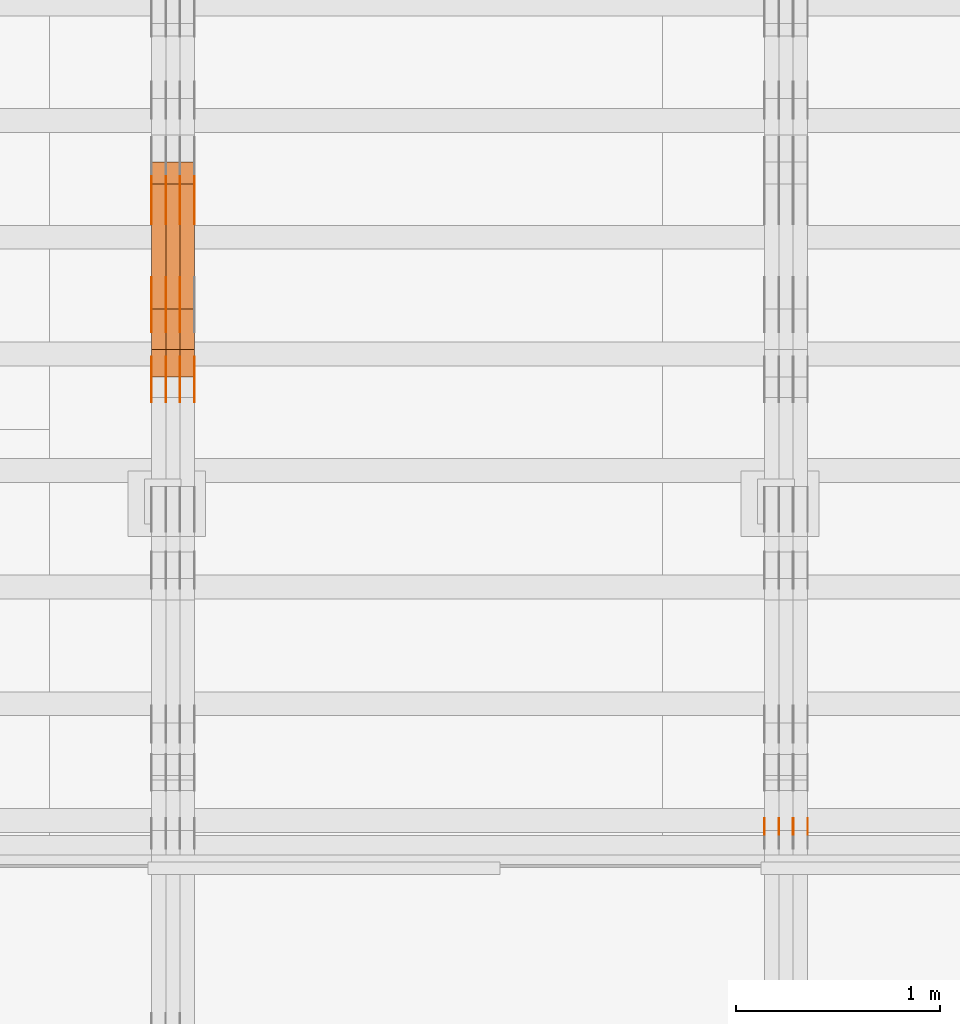
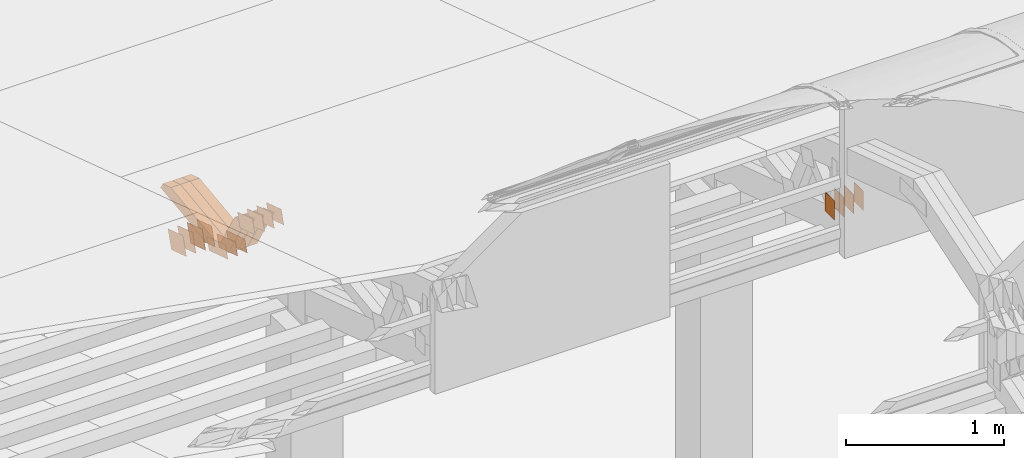
# One storey, part 101 of 385: 29 proxies.
"""IFC2X3 building model written with IfcOpenShell, lengths in millimetres."""

from ifc_helpers import new_model, entity, si_unit, converted_unit, derived_unit, direction, frame, origin, origin_2d_with_axis, place, context, subcontext, project, spatial, polyline, rectangle, outline, extrude, source, transform, mapped, material, type_object, type_shapes, element, save


model = new_model("IFC2X3")

# Units and contexts
model_context = context("Model", 3, precision=0.01, world=origin(), true_north=direction((6.12303176911189e-17, 1.0)))
body_context = subcontext(model_context, "Body", "Model", "MODEL_VIEW")
ifc_project = project(units=[si_unit("LENGTHUNIT", "METRE", prefix="MILLI"), si_unit("AREAUNIT", "SQUARE_METRE"), si_unit("VOLUMEUNIT", "CUBIC_METRE"), converted_unit("PLANEANGLEUNIT", "DEGREE", entity("IfcRatioMeasure", 0.0174532925199433), si_unit("PLANEANGLEUNIT", "RADIAN"), dimensions=[0, 0, 0, 0, 0, 0, 0]), si_unit("MASSUNIT", "GRAM", prefix="KILO"), derived_unit("MASSDENSITYUNIT", [(si_unit("MASSUNIT", "GRAM", prefix="KILO"), 1), (si_unit("LENGTHUNIT", "METRE"), -3)]), si_unit("TIMEUNIT", "SECOND"), si_unit("FREQUENCYUNIT", "HERTZ"), si_unit("THERMODYNAMICTEMPERATUREUNIT", "DEGREE_CELSIUS"), derived_unit("THERMALTRANSMITTANCEUNIT", [(si_unit("MASSUNIT", "GRAM", prefix="KILO"), 1), (si_unit("THERMODYNAMICTEMPERATUREUNIT", "KELVIN"), -1), (si_unit("TIMEUNIT", "SECOND"), -3)]), derived_unit("VOLUMETRICFLOWRATEUNIT", [(si_unit("LENGTHUNIT", "METRE"), 3), (si_unit("TIMEUNIT", "SECOND"), -1)]), si_unit("ELECTRICCURRENTUNIT", "AMPERE"), si_unit("ELECTRICVOLTAGEUNIT", "VOLT"), si_unit("POWERUNIT", "WATT"), si_unit("FORCEUNIT", "NEWTON", prefix="KILO"), si_unit("ILLUMINANCEUNIT", "LUX"), si_unit("LUMINOUSFLUXUNIT", "LUMEN"), si_unit("LUMINOUSINTENSITYUNIT", "CANDELA"), derived_unit("USERDEFINED", [(si_unit("MASSUNIT", "GRAM", prefix="KILO"), -1), (si_unit("LENGTHUNIT", "METRE"), -2), (si_unit("TIMEUNIT", "SECOND"), 3), (si_unit("LUMINOUSFLUXUNIT", "LUMEN"), 1)]), derived_unit("LINEARVELOCITYUNIT", [(si_unit("LENGTHUNIT", "METRE"), 1), (si_unit("TIMEUNIT", "SECOND"), -1)]), si_unit("PRESSUREUNIT", "PASCAL"), derived_unit("USERDEFINED", [(si_unit("LENGTHUNIT", "METRE"), -2), (si_unit("MASSUNIT", "GRAM", prefix="KILO"), 1), (si_unit("TIMEUNIT", "SECOND"), -2)])], contexts=[model_context])

# Site, building, storey
site_placement = place(None, origin())
site = spatial("IfcSite", under=ifc_project, at=site_placement, CompositionType="ELEMENT")
building_placement = place(site_placement, origin())
building = spatial("IfcBuilding", under=site, at=building_placement, CompositionType="ELEMENT")
storey_placement = place(building_placement, origin())
storey = spatial("IfcBuildingStorey", under=building, at=storey_placement, Name="Default", CompositionType="ELEMENT", Elevation=0.0)

# Proxies
ifc_material_1 = material(Name="IfcSurfaceStyle #170946")
building_element_proxy_type_1 = type_object("IfcBuildingElementProxyType", PredefinedType="NOTDEFINED", material=ifc_material_1)
shared_shape_1 = source(origin(), body_context, "Body", "SweptSolid", [
    extrude(rectangle(XDim=150.0, YDim=120.0, at=origin_2d_with_axis()), frame((75.0, 60.0, 0.0), z_axis=(0.0, 0.0, 1.0), x_axis=(-1.0, 0.0, 0.0)), (0.0, 0.0, 1.0), 1.3),
])
type_shapes(building_element_proxy_type_1, [shared_shape_1])
proxy_1_placement = place(building_placement, frame((12386.3, 15840.0, 3652.70166015625), z_axis=(-1.0, 0.0, 0.0), x_axis=(0.0, 0.0, -1.0)))
element("IfcBuildingElementProxy", 1, at=proxy_1_placement, inside=storey, type_object=building_element_proxy_type_1, material=ifc_material_1, context=body_context, shape_type="MappedRepresentation", body=[
    mapped(shared_shape_1, transform((0.0, 0.0, 0.0), scale=1.0)),
])
ifc_material_2 = material(Name="IfcSurfaceStyle #170889")
building_element_proxy_type_2 = type_object("IfcBuildingElementProxyType", PredefinedType="NOTDEFINED", material=ifc_material_2)
shared_shape_2 = source(origin(), body_context, "Body", "SweptSolid", [
    extrude(rectangle(XDim=150.0, YDim=120.0, at=origin_2d_with_axis()), frame((75.0, 60.0, 0.0), z_axis=(0.0, 0.0, 1.0), x_axis=(-1.0, 0.0, 0.0)), (0.0, 0.0, 1.0), 1.3),
])
type_shapes(building_element_proxy_type_2, [shared_shape_2])
proxy_2_placement = place(building_placement, frame((12315.0, 15840.0, 3652.70166015625), z_axis=(-1.0, 0.0, 0.0), x_axis=(0.0, 0.0, -1.0)))
element("IfcBuildingElementProxy", 2, at=proxy_2_placement, inside=storey, type_object=building_element_proxy_type_2, material=ifc_material_2, context=body_context, shape_type="MappedRepresentation", body=[
    mapped(shared_shape_2, transform((0.0, 0.0, 0.0), scale=1.0)),
])
ifc_material_3 = material(Name="IfcSurfaceStyle #170832")
building_element_proxy_type_3 = type_object("IfcBuildingElementProxyType", PredefinedType="NOTDEFINED", material=ifc_material_3)
shared_shape_3 = source(origin(), body_context, "Body", "SweptSolid", [
    extrude(rectangle(XDim=150.0, YDim=120.0, at=origin_2d_with_axis()), frame((75.0, 60.0, 0.0), z_axis=(0.0, 0.0, 1.0), x_axis=(-1.0, 0.0, 0.0)), (0.0, 0.0, 1.0), 1.3),
])
type_shapes(building_element_proxy_type_3, [shared_shape_3])
proxy_3_placement = place(building_placement, frame((12316.3, 15840.0, 3652.70166015625), z_axis=(-1.0, 0.0, 0.0), x_axis=(0.0, 0.0, -1.0)))
element("IfcBuildingElementProxy", 3, at=proxy_3_placement, inside=storey, type_object=building_element_proxy_type_3, material=ifc_material_3, context=body_context, shape_type="MappedRepresentation", body=[
    mapped(shared_shape_3, transform((0.0, 0.0, 0.0), scale=1.0)),
])
ifc_material_4 = material(Name="IfcSurfaceStyle #170775")
building_element_proxy_type_4 = type_object("IfcBuildingElementProxyType", PredefinedType="NOTDEFINED", material=ifc_material_4)
shared_shape_4 = source(origin(), body_context, "Body", "SweptSolid", [
    extrude(rectangle(XDim=150.0, YDim=120.0, at=origin_2d_with_axis()), frame((75.0, 60.0, 0.0), z_axis=(0.0, 0.0, 1.0), x_axis=(-1.0, 0.0, 0.0)), (0.0, 0.0, 1.0), 1.29999999999999),
])
type_shapes(building_element_proxy_type_4, [shared_shape_4])
proxy_4_placement = place(building_placement, frame((12245.0, 15840.0, 3652.70166015625), z_axis=(-1.0, 0.0, 0.0), x_axis=(0.0, 0.0, -1.0)))
element("IfcBuildingElementProxy", 4, at=proxy_4_placement, inside=storey, type_object=building_element_proxy_type_4, material=ifc_material_4, context=body_context, shape_type="MappedRepresentation", body=[
    mapped(shared_shape_4, transform((0.0, 0.0, 0.0), scale=1.0)),
])
ifc_material_5 = material(Name="IfcSurfaceStyle #170718")
building_element_proxy_type_5 = type_object("IfcBuildingElementProxyType", PredefinedType="NOTDEFINED", material=ifc_material_5)
shared_shape_5 = source(origin(), body_context, "Body", "SweptSolid", [
    extrude(rectangle(XDim=150.0, YDim=120.0, at=origin_2d_with_axis()), frame((75.0, 60.0, 0.0), z_axis=(0.0, 0.0, 1.0), x_axis=(-1.0, 0.0, 0.0)), (0.0, 0.0, 1.0), 1.29999999999999),
])
type_shapes(building_element_proxy_type_5, [shared_shape_5])
proxy_5_placement = place(building_placement, frame((12246.3, 15840.0, 3652.70166015625), z_axis=(-1.0, 0.0, 0.0), x_axis=(0.0, 0.0, -1.0)))
element("IfcBuildingElementProxy", 5, at=proxy_5_placement, inside=storey, type_object=building_element_proxy_type_5, material=ifc_material_5, context=body_context, shape_type="MappedRepresentation", body=[
    mapped(shared_shape_5, transform((0.0, 0.0, 0.0), scale=1.0)),
])
ifc_material_6 = material(Name="IfcSurfaceStyle #170661")
building_element_proxy_type_6 = type_object("IfcBuildingElementProxyType", PredefinedType="NOTDEFINED", material=ifc_material_6)
shared_shape_6 = source(origin(), body_context, "Body", "SweptSolid", [
    extrude(rectangle(XDim=150.0, YDim=120.0, at=origin_2d_with_axis()), frame((75.0, 60.0, 0.0), z_axis=(0.0, 0.0, 1.0), x_axis=(-1.0, 0.0, 0.0)), (0.0, 0.0, 1.0), 1.29999999999999),
])
type_shapes(building_element_proxy_type_6, [shared_shape_6])
proxy_6_placement = place(building_placement, frame((12175.0, 15840.0, 3652.70166015625), z_axis=(-1.0, 0.0, 0.0), x_axis=(0.0, 0.0, -1.0)))
element("IfcBuildingElementProxy", 6, at=proxy_6_placement, inside=storey, type_object=building_element_proxy_type_6, material=ifc_material_6, context=body_context, shape_type="MappedRepresentation", body=[
    mapped(shared_shape_6, transform((0.0, 0.0, 0.0), scale=1.0)),
])
ifc_material_7 = material(Name="IfcSurfaceStyle #135773")
building_element_proxy_type_7 = type_object("IfcBuildingElementProxyType", PredefinedType="NOTDEFINED", material=ifc_material_7)
shared_shape_7 = source(origin(), body_context, "Body", "SweptSolid", [
    extrude(outline(polyline([(-125.00031378339, -47.9999612158856), (125.000225258022, -47.9999612158856), (124.999811678525, 47.9999612158856), (-124.999723153156, 47.9999612158856), (-125.00031378339, -47.9999612158856)])), frame((125.000225258022, 48.0000091013474, 0.0), z_axis=(0.0, 0.0, 1.0), x_axis=(-1.0, 0.0, 0.0)), (0.0, 0.0, 1.0), 1.3),
])
type_shapes(building_element_proxy_type_7, [shared_shape_7])
proxy_7_placement = place(building_placement, frame((9315.0, 18456.8597683375, 2657.46691321253), z_axis=(-1.0, 0.0, 0.0), x_axis=(0.0, -0.951056516295124, 0.309016994375039)))
element("IfcBuildingElementProxy", 7, at=proxy_7_placement, inside=storey, type_object=building_element_proxy_type_7, material=ifc_material_7, context=body_context, shape_type="MappedRepresentation", body=[
    mapped(shared_shape_7, transform((0.0, 0.0, 0.0), scale=1.0)),
])
ifc_material_8 = material(Name="IfcSurfaceStyle #135716")
building_element_proxy_type_8 = type_object("IfcBuildingElementProxyType", PredefinedType="NOTDEFINED", material=ifc_material_8)
shared_shape_8 = source(origin(), body_context, "Body", "SweptSolid", [
    extrude(outline(polyline([(-125.00031378339, -47.9999612158856), (125.000225258022, -47.9999612158856), (124.999811678525, 47.9999612158856), (-124.999723153156, 47.9999612158856), (-125.00031378339, -47.9999612158856)])), frame((125.000225258022, 48.0000091013474, 0.0), z_axis=(0.0, 0.0, 1.0), x_axis=(-1.0, 0.0, 0.0)), (0.0, 0.0, 1.0), 1.3),
])
type_shapes(building_element_proxy_type_8, [shared_shape_8])
proxy_8_placement = place(building_placement, frame((9316.29999999998, 18456.8597683375, 2657.46691321253), z_axis=(-1.0, 0.0, 0.0), x_axis=(0.0, -0.951056516295124, 0.309016994375039)))
element("IfcBuildingElementProxy", 8, at=proxy_8_placement, inside=storey, type_object=building_element_proxy_type_8, material=ifc_material_8, context=body_context, shape_type="MappedRepresentation", body=[
    mapped(shared_shape_8, transform((0.0, 0.0, 0.0), scale=1.0)),
])
ifc_material_9 = material(Name="IfcSurfaceStyle #135659")
building_element_proxy_type_9 = type_object("IfcBuildingElementProxyType", PredefinedType="NOTDEFINED", material=ifc_material_9)
shared_shape_9 = source(origin(), body_context, "Body", "SweptSolid", [
    extrude(outline(polyline([(-125.00031378339, -47.9999612158856), (125.000225258022, -47.9999612158856), (124.999811678525, 47.9999612158856), (-124.999723153156, 47.9999612158856), (-125.00031378339, -47.9999612158856)])), frame((125.000225258022, 48.0000091013474, 0.0), z_axis=(0.0, 0.0, 1.0), x_axis=(-1.0, 0.0, 0.0)), (0.0, 0.0, 1.0), 1.29999999999998),
])
type_shapes(building_element_proxy_type_9, [shared_shape_9])
proxy_9_placement = place(building_placement, frame((9245.0, 18456.8597683375, 2657.46691321253), z_axis=(-1.0, 0.0, 0.0), x_axis=(0.0, -0.951056516295124, 0.309016994375039)))
element("IfcBuildingElementProxy", 9, at=proxy_9_placement, inside=storey, type_object=building_element_proxy_type_9, material=ifc_material_9, context=body_context, shape_type="MappedRepresentation", body=[
    mapped(shared_shape_9, transform((0.0, 0.0, 0.0), scale=1.0)),
])
ifc_material_10 = material(Name="IfcSurfaceStyle #135602")
building_element_proxy_type_10 = type_object("IfcBuildingElementProxyType", PredefinedType="NOTDEFINED", material=ifc_material_10)
shared_shape_10 = source(origin(), body_context, "Body", "SweptSolid", [
    extrude(outline(polyline([(-125.00031378339, -47.9999612158856), (125.000225258022, -47.9999612158856), (124.999811678525, 47.9999612158856), (-124.999723153156, 47.9999612158856), (-125.00031378339, -47.9999612158856)])), frame((125.000225258022, 48.0000091013474, 0.0), z_axis=(0.0, 0.0, 1.0), x_axis=(-1.0, 0.0, 0.0)), (0.0, 0.0, 1.0), 1.29999999999998),
])
type_shapes(building_element_proxy_type_10, [shared_shape_10])
proxy_10_placement = place(building_placement, frame((9246.29999999998, 18456.8597683375, 2657.46691321253), z_axis=(-1.0, 0.0, 0.0), x_axis=(0.0, -0.951056516295124, 0.309016994375039)))
element("IfcBuildingElementProxy", 10, at=proxy_10_placement, inside=storey, type_object=building_element_proxy_type_10, material=ifc_material_10, context=body_context, shape_type="MappedRepresentation", body=[
    mapped(shared_shape_10, transform((0.0, 0.0, 0.0), scale=1.0)),
])
ifc_material_11 = material(Name="IfcSurfaceStyle #135545")
building_element_proxy_type_11 = type_object("IfcBuildingElementProxyType", PredefinedType="NOTDEFINED", material=ifc_material_11)
shared_shape_11 = source(origin(), body_context, "Body", "SweptSolid", [
    extrude(outline(polyline([(-125.00031378339, -47.9999612158856), (125.000225258022, -47.9999612158856), (124.999811678525, 47.9999612158856), (-124.999723153156, 47.9999612158856), (-125.00031378339, -47.9999612158856)])), frame((125.000225258022, 48.0000091013474, 0.0), z_axis=(0.0, 0.0, 1.0), x_axis=(-1.0, 0.0, 0.0)), (0.0, 0.0, 1.0), 1.29999999999998),
])
type_shapes(building_element_proxy_type_11, [shared_shape_11])
proxy_11_placement = place(building_placement, frame((9175.0, 18456.8597683375, 2657.46691321253), z_axis=(-1.0, 0.0, 0.0), x_axis=(0.0, -0.951056516295124, 0.309016994375039)))
element("IfcBuildingElementProxy", 11, at=proxy_11_placement, inside=storey, type_object=building_element_proxy_type_11, material=ifc_material_11, context=body_context, shape_type="MappedRepresentation", body=[
    mapped(shared_shape_11, transform((0.0, 0.0, 0.0), scale=1.0)),
])
ifc_material_12 = material(Name="IfcSurfaceStyle #134120")
building_element_proxy_type_12 = type_object("IfcBuildingElementProxyType", PredefinedType="NOTDEFINED", material=ifc_material_12)
shared_shape_12 = source(origin(), body_context, "Body", "SweptSolid", [
    extrude(outline(polyline([(-99.999796294464, -72.0000050220467), (99.9998768370438, -72.0000050220467), (100.000260677528, 72.0000050220467), (-100.000341220108, 72.0000050220467), (-99.999796294464, -72.0000050220467)])), frame((100.000260677528, 72.0000050220467, 0.0), z_axis=(0.0, 0.0, 1.0), x_axis=(-1.0, 0.0, 0.0)), (0.0, 0.0, 1.0), 1.3),
])
type_shapes(building_element_proxy_type_12, [shared_shape_12])
proxy_12_placement = place(building_placement, frame((9386.29999999998, 18936.3876569477, 2373.90613192527), z_axis=(-1.0, 0.0, 0.0), x_axis=(0.0, -0.951056516295124, 0.309016994375039)))
element("IfcBuildingElementProxy", 12, at=proxy_12_placement, inside=storey, type_object=building_element_proxy_type_12, material=ifc_material_12, context=body_context, shape_type="MappedRepresentation", body=[
    mapped(shared_shape_12, transform((0.0, 0.0, 0.0), scale=1.0)),
])
ifc_material_13 = material(Name="IfcSurfaceStyle #134063")
building_element_proxy_type_13 = type_object("IfcBuildingElementProxyType", PredefinedType="NOTDEFINED", material=ifc_material_13)
shared_shape_13 = source(origin(), body_context, "Body", "SweptSolid", [
    extrude(outline(polyline([(-99.999796294464, -72.0000050220467), (99.9998768370438, -72.0000050220467), (100.000260677528, 72.0000050220467), (-100.000341220108, 72.0000050220467), (-99.999796294464, -72.0000050220467)])), frame((100.000260677528, 72.0000050220467, 0.0), z_axis=(0.0, 0.0, 1.0), x_axis=(-1.0, 0.0, 0.0)), (0.0, 0.0, 1.0), 1.3),
])
type_shapes(building_element_proxy_type_13, [shared_shape_13])
proxy_13_placement = place(building_placement, frame((9315.0, 18936.3876569477, 2373.90613192527), z_axis=(-1.0, 0.0, 0.0), x_axis=(0.0, -0.951056516295124, 0.309016994375039)))
element("IfcBuildingElementProxy", 13, at=proxy_13_placement, inside=storey, type_object=building_element_proxy_type_13, material=ifc_material_13, context=body_context, shape_type="MappedRepresentation", body=[
    mapped(shared_shape_13, transform((0.0, 0.0, 0.0), scale=1.0)),
])
ifc_material_14 = material(Name="IfcSurfaceStyle #134006")
building_element_proxy_type_14 = type_object("IfcBuildingElementProxyType", PredefinedType="NOTDEFINED", material=ifc_material_14)
shared_shape_14 = source(origin(), body_context, "Body", "SweptSolid", [
    extrude(outline(polyline([(-99.999796294464, -72.0000050220467), (99.9998768370438, -72.0000050220467), (100.000260677528, 72.0000050220467), (-100.000341220108, 72.0000050220467), (-99.999796294464, -72.0000050220467)])), frame((100.000260677528, 72.0000050220467, 0.0), z_axis=(0.0, 0.0, 1.0), x_axis=(-1.0, 0.0, 0.0)), (0.0, 0.0, 1.0), 1.3),
])
type_shapes(building_element_proxy_type_14, [shared_shape_14])
proxy_14_placement = place(building_placement, frame((9316.29999999998, 18936.3876569477, 2373.90613192527), z_axis=(-1.0, 0.0, 0.0), x_axis=(0.0, -0.951056516295124, 0.309016994375039)))
element("IfcBuildingElementProxy", 14, at=proxy_14_placement, inside=storey, type_object=building_element_proxy_type_14, material=ifc_material_14, context=body_context, shape_type="MappedRepresentation", body=[
    mapped(shared_shape_14, transform((0.0, 0.0, 0.0), scale=1.0)),
])
ifc_material_15 = material(Name="IfcSurfaceStyle #133949")
building_element_proxy_type_15 = type_object("IfcBuildingElementProxyType", PredefinedType="NOTDEFINED", material=ifc_material_15)
shared_shape_15 = source(origin(), body_context, "Body", "SweptSolid", [
    extrude(outline(polyline([(-99.999796294464, -72.0000050220467), (99.9998768370438, -72.0000050220467), (100.000260677528, 72.0000050220467), (-100.000341220108, 72.0000050220467), (-99.999796294464, -72.0000050220467)])), frame((100.000260677528, 72.0000050220467, 0.0), z_axis=(0.0, 0.0, 1.0), x_axis=(-1.0, 0.0, 0.0)), (0.0, 0.0, 1.0), 1.29999999999998),
])
type_shapes(building_element_proxy_type_15, [shared_shape_15])
proxy_15_placement = place(building_placement, frame((9245.0, 18936.3876569477, 2373.90613192527), z_axis=(-1.0, 0.0, 0.0), x_axis=(0.0, -0.951056516295124, 0.309016994375039)))
element("IfcBuildingElementProxy", 15, at=proxy_15_placement, inside=storey, type_object=building_element_proxy_type_15, material=ifc_material_15, context=body_context, shape_type="MappedRepresentation", body=[
    mapped(shared_shape_15, transform((0.0, 0.0, 0.0), scale=1.0)),
])
ifc_material_16 = material(Name="IfcSurfaceStyle #133892")
building_element_proxy_type_16 = type_object("IfcBuildingElementProxyType", PredefinedType="NOTDEFINED", material=ifc_material_16)
shared_shape_16 = source(origin(), body_context, "Body", "SweptSolid", [
    extrude(outline(polyline([(-99.999796294464, -72.0000050220467), (99.9998768370438, -72.0000050220467), (100.000260677528, 72.0000050220467), (-100.000341220108, 72.0000050220467), (-99.999796294464, -72.0000050220467)])), frame((100.000260677528, 72.0000050220467, 0.0), z_axis=(0.0, 0.0, 1.0), x_axis=(-1.0, 0.0, 0.0)), (0.0, 0.0, 1.0), 1.29999999999998),
])
type_shapes(building_element_proxy_type_16, [shared_shape_16])
proxy_16_placement = place(building_placement, frame((9246.29999999998, 18936.3876569477, 2373.90613192527), z_axis=(-1.0, 0.0, 0.0), x_axis=(0.0, -0.951056516295124, 0.309016994375039)))
element("IfcBuildingElementProxy", 16, at=proxy_16_placement, inside=storey, type_object=building_element_proxy_type_16, material=ifc_material_16, context=body_context, shape_type="MappedRepresentation", body=[
    mapped(shared_shape_16, transform((0.0, 0.0, 0.0), scale=1.0)),
])
ifc_material_17 = material(Name="IfcSurfaceStyle #133835")
building_element_proxy_type_17 = type_object("IfcBuildingElementProxyType", PredefinedType="NOTDEFINED", material=ifc_material_17)
shared_shape_17 = source(origin(), body_context, "Body", "SweptSolid", [
    extrude(outline(polyline([(-99.999796294464, -72.0000050220467), (99.9998768370438, -72.0000050220467), (100.000260677528, 72.0000050220467), (-100.000341220108, 72.0000050220467), (-99.999796294464, -72.0000050220467)])), frame((100.000260677528, 72.0000050220467, 0.0), z_axis=(0.0, 0.0, 1.0), x_axis=(-1.0, 0.0, 0.0)), (0.0, 0.0, 1.0), 1.29999999999999),
])
type_shapes(building_element_proxy_type_17, [shared_shape_17])
proxy_17_placement = place(building_placement, frame((9175.0, 18936.3876569477, 2373.90613192527), z_axis=(-1.0, 0.0, 0.0), x_axis=(0.0, -0.951056516295124, 0.309016994375039)))
element("IfcBuildingElementProxy", 17, at=proxy_17_placement, inside=storey, type_object=building_element_proxy_type_17, material=ifc_material_17, context=body_context, shape_type="MappedRepresentation", body=[
    mapped(shared_shape_17, transform((0.0, 0.0, 0.0), scale=1.0)),
])
ifc_material_18 = material(Name="IfcSurfaceStyle #129674")
building_element_proxy_type_18 = type_object("IfcBuildingElementProxyType", PredefinedType="NOTDEFINED", material=ifc_material_18)
shared_shape_18 = source(origin(), body_context, "Body", "SweptSolid", [
    extrude(outline(polyline([(-99.9999427841299, -54.0000599375792), (99.9996549037756, -54.0000599375792), (100.000407167194, 54.0000599375792), (-100.00011928684, 54.0000599375792), (-99.9999427841299, -54.0000599375792)])), frame((100.000407167194, 54.0000599375792, 0.0), z_axis=(0.0, 0.0, 1.0), x_axis=(-1.0, 0.0, 0.0)), (0.0, 0.0, 1.0), 1.3),
])
type_shapes(building_element_proxy_type_18, [shared_shape_18])
proxy_18_placement = place(building_placement, frame((9386.29999999998, 18065.0682492591, 3072.55239547302), z_axis=(-1.0, 0.0, 0.0), x_axis=(0.0, -0.951056516295154, 0.309016994374948)))
element("IfcBuildingElementProxy", 18, at=proxy_18_placement, inside=storey, type_object=building_element_proxy_type_18, material=ifc_material_18, context=body_context, shape_type="MappedRepresentation", body=[
    mapped(shared_shape_18, transform((0.0, 0.0, 0.0), scale=1.0)),
])
ifc_material_19 = material(Name="IfcSurfaceStyle #129617")
building_element_proxy_type_19 = type_object("IfcBuildingElementProxyType", PredefinedType="NOTDEFINED", material=ifc_material_19)
shared_shape_19 = source(origin(), body_context, "Body", "SweptSolid", [
    extrude(outline(polyline([(-99.9999427841299, -54.0000599375792), (99.9996549037756, -54.0000599375792), (100.000407167194, 54.0000599375792), (-100.00011928684, 54.0000599375792), (-99.9999427841299, -54.0000599375792)])), frame((100.000407167194, 54.0000599375792, 0.0), z_axis=(0.0, 0.0, 1.0), x_axis=(-1.0, 0.0, 0.0)), (0.0, 0.0, 1.0), 1.3),
])
type_shapes(building_element_proxy_type_19, [shared_shape_19])
proxy_19_placement = place(building_placement, frame((9315.0, 18065.0682492591, 3072.55239547302), z_axis=(-1.0, 0.0, 0.0), x_axis=(0.0, -0.951056516295154, 0.309016994374948)))
element("IfcBuildingElementProxy", 19, at=proxy_19_placement, inside=storey, type_object=building_element_proxy_type_19, material=ifc_material_19, context=body_context, shape_type="MappedRepresentation", body=[
    mapped(shared_shape_19, transform((0.0, 0.0, 0.0), scale=1.0)),
])
ifc_material_20 = material(Name="IfcSurfaceStyle #129560")
building_element_proxy_type_20 = type_object("IfcBuildingElementProxyType", PredefinedType="NOTDEFINED", material=ifc_material_20)
shared_shape_20 = source(origin(), body_context, "Body", "SweptSolid", [
    extrude(outline(polyline([(-99.9999427841299, -54.0000599375792), (99.9996549037756, -54.0000599375792), (100.000407167194, 54.0000599375792), (-100.00011928684, 54.0000599375792), (-99.9999427841299, -54.0000599375792)])), frame((100.000407167194, 54.0000599375792, 0.0), z_axis=(0.0, 0.0, 1.0), x_axis=(-1.0, 0.0, 0.0)), (0.0, 0.0, 1.0), 1.3),
])
type_shapes(building_element_proxy_type_20, [shared_shape_20])
proxy_20_placement = place(building_placement, frame((9316.29999999998, 18065.0682492591, 3072.55239547302), z_axis=(-1.0, 0.0, 0.0), x_axis=(0.0, -0.951056516295154, 0.309016994374948)))
element("IfcBuildingElementProxy", 20, at=proxy_20_placement, inside=storey, type_object=building_element_proxy_type_20, material=ifc_material_20, context=body_context, shape_type="MappedRepresentation", body=[
    mapped(shared_shape_20, transform((0.0, 0.0, 0.0), scale=1.0)),
])
ifc_material_21 = material(Name="IfcSurfaceStyle #129503")
building_element_proxy_type_21 = type_object("IfcBuildingElementProxyType", PredefinedType="NOTDEFINED", material=ifc_material_21)
shared_shape_21 = source(origin(), body_context, "Body", "SweptSolid", [
    extrude(outline(polyline([(-99.9999427841299, -54.0000599375792), (99.9996549037756, -54.0000599375792), (100.000407167194, 54.0000599375792), (-100.00011928684, 54.0000599375792), (-99.9999427841299, -54.0000599375792)])), frame((100.000407167194, 54.0000599375792, 0.0), z_axis=(0.0, 0.0, 1.0), x_axis=(-1.0, 0.0, 0.0)), (0.0, 0.0, 1.0), 1.29999999999998),
])
type_shapes(building_element_proxy_type_21, [shared_shape_21])
proxy_21_placement = place(building_placement, frame((9245.0, 18065.0682492591, 3072.55239547302), z_axis=(-1.0, 0.0, 0.0), x_axis=(0.0, -0.951056516295154, 0.309016994374948)))
element("IfcBuildingElementProxy", 21, at=proxy_21_placement, inside=storey, type_object=building_element_proxy_type_21, material=ifc_material_21, context=body_context, shape_type="MappedRepresentation", body=[
    mapped(shared_shape_21, transform((0.0, 0.0, 0.0), scale=1.0)),
])
ifc_material_22 = material(Name="IfcSurfaceStyle #129446")
building_element_proxy_type_22 = type_object("IfcBuildingElementProxyType", PredefinedType="NOTDEFINED", material=ifc_material_22)
shared_shape_22 = source(origin(), body_context, "Body", "SweptSolid", [
    extrude(outline(polyline([(-99.9999427841299, -54.0000599375792), (99.9996549037756, -54.0000599375792), (100.000407167194, 54.0000599375792), (-100.00011928684, 54.0000599375792), (-99.9999427841299, -54.0000599375792)])), frame((100.000407167194, 54.0000599375792, 0.0), z_axis=(0.0, 0.0, 1.0), x_axis=(-1.0, 0.0, 0.0)), (0.0, 0.0, 1.0), 1.29999999999998),
])
type_shapes(building_element_proxy_type_22, [shared_shape_22])
proxy_22_placement = place(building_placement, frame((9246.29999999998, 18065.0682492591, 3072.55239547302), z_axis=(-1.0, 0.0, 0.0), x_axis=(0.0, -0.951056516295154, 0.309016994374948)))
element("IfcBuildingElementProxy", 22, at=proxy_22_placement, inside=storey, type_object=building_element_proxy_type_22, material=ifc_material_22, context=body_context, shape_type="MappedRepresentation", body=[
    mapped(shared_shape_22, transform((0.0, 0.0, 0.0), scale=1.0)),
])
ifc_material_23 = material(Name="IfcSurfaceStyle #129389")
building_element_proxy_type_23 = type_object("IfcBuildingElementProxyType", PredefinedType="NOTDEFINED", material=ifc_material_23)
shared_shape_23 = source(origin(), body_context, "Body", "SweptSolid", [
    extrude(outline(polyline([(-99.9999427841299, -54.0000599375792), (99.9996549037756, -54.0000599375792), (100.000407167194, 54.0000599375792), (-100.00011928684, 54.0000599375792), (-99.9999427841299, -54.0000599375792)])), frame((100.000407167194, 54.0000599375792, 0.0), z_axis=(0.0, 0.0, 1.0), x_axis=(-1.0, 0.0, 0.0)), (0.0, 0.0, 1.0), 1.29999999999999),
])
type_shapes(building_element_proxy_type_23, [shared_shape_23])
proxy_23_placement = place(building_placement, frame((9175.0, 18065.0682492591, 3072.55239547302), z_axis=(-1.0, 0.0, 0.0), x_axis=(0.0, -0.951056516295154, 0.309016994374948)))
element("IfcBuildingElementProxy", 23, at=proxy_23_placement, inside=storey, type_object=building_element_proxy_type_23, material=ifc_material_23, context=body_context, shape_type="MappedRepresentation", body=[
    mapped(shared_shape_23, transform((0.0, 0.0, 0.0), scale=1.0)),
])
ifc_material_24 = material(Name="IfcSurfaceStyle #119522")
building_element_proxy_type_24 = type_object("IfcBuildingElementProxyType", Name="T1-W35 119520", PredefinedType="NOTDEFINED", material=ifc_material_24)
shared_shape_24 = source(origin(), body_context, "Body", "SweptSolid", [
    extrude(outline(polyline([(-196.877231354918, -47.499850828051), (197.289756738813, -47.499850828051), (177.380838136073, -0.000131002767018074), (124.615181369032, 47.4999163294346), (-302.408544889, 47.4999163294346), (-196.877231354918, -47.499850828051)])), frame((197.289756738813, 47.5002438363521, 0.0), z_axis=(0.0, 0.0, 1.0), x_axis=(-1.0, 0.0, 0.0)), (0.0, 0.0, 1.0), 70.0),
])
type_shapes(building_element_proxy_type_24, [shared_shape_24])
proxy_24_placement = place(building_placement, frame((9385.0, 18249.5528960018, 2724.16980022534), z_axis=(-1.0, 0.0, 0.0), x_axis=(0.0, -0.5, 0.866025403784439)))
element("IfcBuildingElementProxy", 24, at=proxy_24_placement, inside=storey, type_object=building_element_proxy_type_24, material=ifc_material_24, Name="T1-W35", context=body_context, shape_type="MappedRepresentation", body=[
    mapped(shared_shape_24, transform((0.0, 0.0, 0.0), scale=1.0)),
])
ifc_material_25 = material(Name="IfcSurfaceStyle #119456")
building_element_proxy_type_25 = type_object("IfcBuildingElementProxyType", Name="T1-W35 119454", PredefinedType="NOTDEFINED", material=ifc_material_25)
shared_shape_25 = source(origin(), body_context, "Body", "SweptSolid", [
    extrude(outline(polyline([(-196.877231354918, -47.499850828051), (197.289756738813, -47.499850828051), (177.380838136073, -0.000131002767018074), (124.615181369032, 47.4999163294346), (-302.408544889, 47.4999163294346), (-196.877231354918, -47.499850828051)])), frame((197.289756738813, 47.5002438363521, 0.0), z_axis=(0.0, 0.0, 1.0), x_axis=(-1.0, 0.0, 0.0)), (0.0, 0.0, 1.0), 70.0),
])
type_shapes(building_element_proxy_type_25, [shared_shape_25])
proxy_25_placement = place(building_placement, frame((9315.0, 18249.5528960018, 2724.16980022534), z_axis=(-1.0, 0.0, 0.0), x_axis=(0.0, -0.5, 0.866025403784439)))
element("IfcBuildingElementProxy", 25, at=proxy_25_placement, inside=storey, type_object=building_element_proxy_type_25, material=ifc_material_25, Name="T1-W35", context=body_context, shape_type="MappedRepresentation", body=[
    mapped(shared_shape_25, transform((0.0, 0.0, 0.0), scale=1.0)),
])
ifc_material_26 = material(Name="IfcSurfaceStyle #119390")
building_element_proxy_type_26 = type_object("IfcBuildingElementProxyType", Name="T1-W35 119388", PredefinedType="NOTDEFINED", material=ifc_material_26)
shared_shape_26 = source(origin(), body_context, "Body", "SweptSolid", [
    extrude(outline(polyline([(-196.877231354918, -47.499850828051), (197.289756738813, -47.499850828051), (177.380838136073, -0.000131002767018074), (124.615181369032, 47.4999163294346), (-302.408544889, 47.4999163294346), (-196.877231354918, -47.499850828051)])), frame((197.289756738813, 47.5002438363521, 0.0), z_axis=(0.0, 0.0, 1.0), x_axis=(-1.0, 0.0, 0.0)), (0.0, 0.0, 1.0), 70.0),
])
type_shapes(building_element_proxy_type_26, [shared_shape_26])
proxy_26_placement = place(building_placement, frame((9245.0, 18249.5528960018, 2724.16980022534), z_axis=(-1.0, 0.0, 0.0), x_axis=(0.0, -0.5, 0.866025403784439)))
element("IfcBuildingElementProxy", 26, at=proxy_26_placement, inside=storey, type_object=building_element_proxy_type_26, material=ifc_material_26, Name="T1-W35", context=body_context, shape_type="MappedRepresentation", body=[
    mapped(shared_shape_26, transform((0.0, 0.0, 0.0), scale=1.0)),
])
ifc_material_27 = material(Name="IfcSurfaceStyle #119126")
building_element_proxy_type_27 = type_object("IfcBuildingElementProxyType", Name="T1-W6 119124", PredefinedType="NOTDEFINED", material=ifc_material_27)
shared_shape_27 = source(origin(), body_context, "Body", "SweptSolid", [
    extrude(outline(polyline([(-485.945461934772, -47.500204767976), (183.41906495488, -47.500204767976), (284.061400026172, 0.000179660053988773), (303.127757064591, 47.500114937949), (-284.66276011087, 47.500114937949), (-485.945461934772, -47.500204767976)])), frame((303.127970456024, 47.5001450766485, 0.0), z_axis=(0.0, 0.0, 1.0), x_axis=(-1.0, 0.0, 0.0)), (0.0, 0.0, 1.0), 70.0),
])
type_shapes(building_element_proxy_type_27, [shared_shape_27])
proxy_27_placement = place(building_placement, frame((9385.0, 19075.4826373647, 2770.72729201433), z_axis=(-1.0, 0.0, 0.0), x_axis=(0.0, -0.991969529622927, -0.126477082112413)))
element("IfcBuildingElementProxy", 27, at=proxy_27_placement, inside=storey, type_object=building_element_proxy_type_27, material=ifc_material_27, Name="T1-W6", context=body_context, shape_type="MappedRepresentation", body=[
    mapped(shared_shape_27, transform((0.0, 0.0, 0.0), scale=1.0)),
])
ifc_material_28 = material(Name="IfcSurfaceStyle #119060")
building_element_proxy_type_28 = type_object("IfcBuildingElementProxyType", Name="T1-W6 119058", PredefinedType="NOTDEFINED", material=ifc_material_28)
shared_shape_28 = source(origin(), body_context, "Body", "SweptSolid", [
    extrude(outline(polyline([(-485.945461934772, -47.500204767976), (183.41906495488, -47.500204767976), (284.061400026172, 0.000179660053988773), (303.127757064591, 47.500114937949), (-284.66276011087, 47.500114937949), (-485.945461934772, -47.500204767976)])), frame((303.127970456024, 47.5001450766485, 0.0), z_axis=(0.0, 0.0, 1.0), x_axis=(-1.0, 0.0, 0.0)), (0.0, 0.0, 1.0), 70.0),
])
type_shapes(building_element_proxy_type_28, [shared_shape_28])
proxy_28_placement = place(building_placement, frame((9315.0, 19075.4826373647, 2770.72729201433), z_axis=(-1.0, 0.0, 0.0), x_axis=(0.0, -0.991969529622927, -0.126477082112413)))
element("IfcBuildingElementProxy", 28, at=proxy_28_placement, inside=storey, type_object=building_element_proxy_type_28, material=ifc_material_28, Name="T1-W6", context=body_context, shape_type="MappedRepresentation", body=[
    mapped(shared_shape_28, transform((0.0, 0.0, 0.0), scale=1.0)),
])
ifc_material_29 = material(Name="IfcSurfaceStyle #118994")
building_element_proxy_type_29 = type_object("IfcBuildingElementProxyType", Name="T1-W6 118992", PredefinedType="NOTDEFINED", material=ifc_material_29)
shared_shape_29 = source(origin(), body_context, "Body", "SweptSolid", [
    extrude(outline(polyline([(-485.945461934772, -47.500204767976), (183.41906495488, -47.500204767976), (284.061400026172, 0.000179660053988773), (303.127757064591, 47.500114937949), (-284.66276011087, 47.500114937949), (-485.945461934772, -47.500204767976)])), frame((303.127970456024, 47.5001450766485, 0.0), z_axis=(0.0, 0.0, 1.0), x_axis=(-1.0, 0.0, 0.0)), (0.0, 0.0, 1.0), 70.0),
])
type_shapes(building_element_proxy_type_29, [shared_shape_29])
proxy_29_placement = place(building_placement, frame((9245.0, 19075.4826373647, 2770.72729201433), z_axis=(-1.0, 0.0, 0.0), x_axis=(0.0, -0.991969529622927, -0.126477082112413)))
element("IfcBuildingElementProxy", 29, at=proxy_29_placement, inside=storey, type_object=building_element_proxy_type_29, material=ifc_material_29, Name="T1-W6", context=body_context, shape_type="MappedRepresentation", body=[
    mapped(shared_shape_29, transform((0.0, 0.0, 0.0), scale=1.0)),
])

save(model, "model.ifc")
